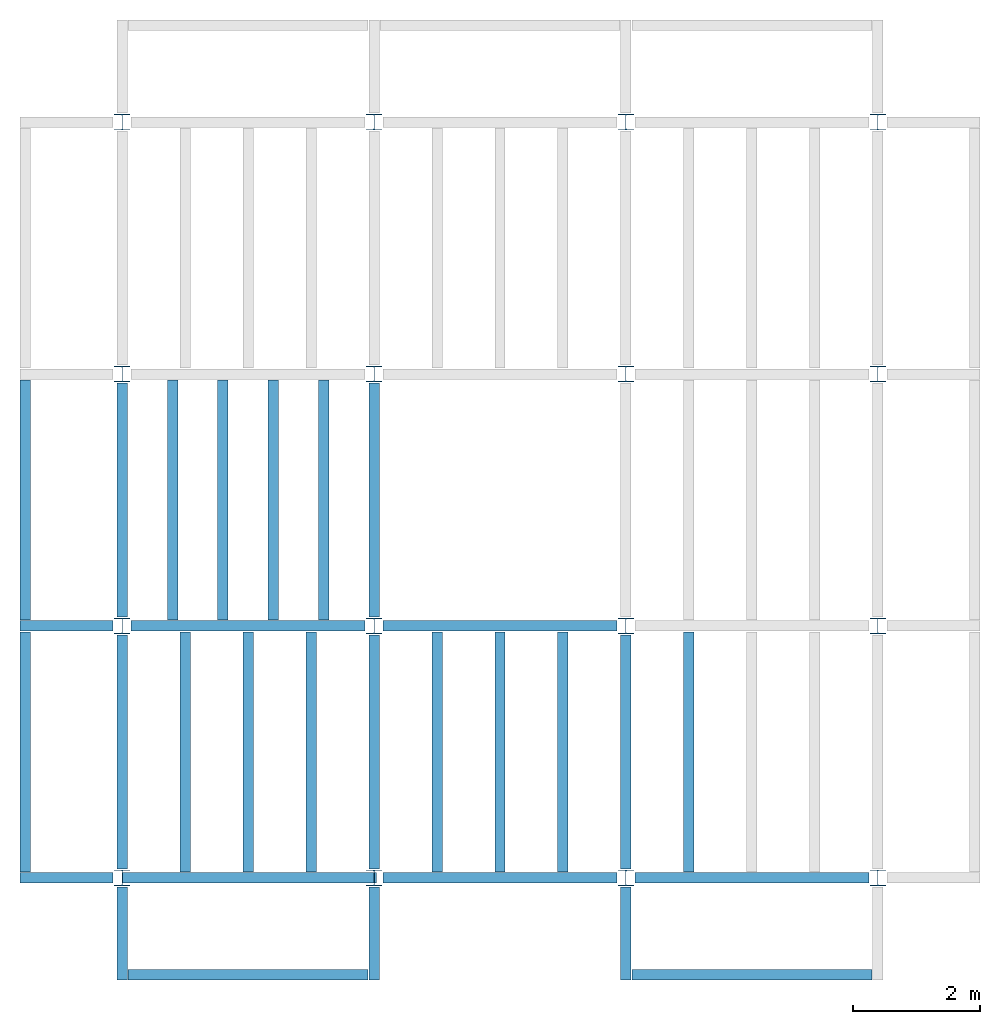
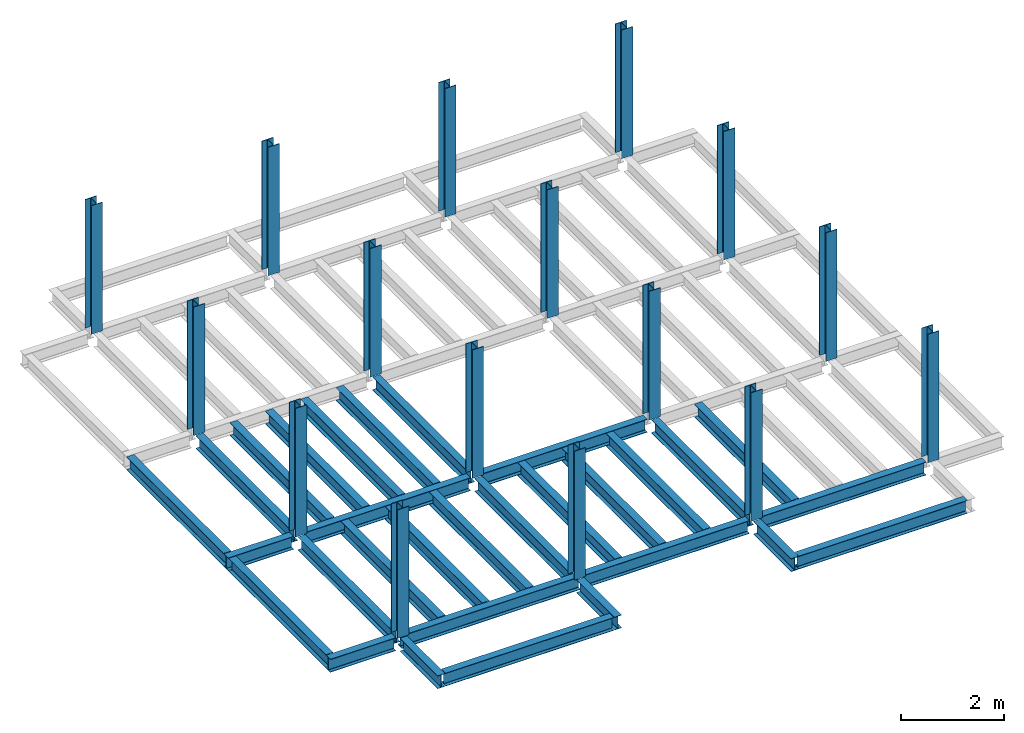
# One storey, part 1 of 3: 30 beams, 16 columns, 4 elements without a shape of their own.
"""IFC4 building model written with IfcOpenShell, lengths in feet."""

from ifc_helpers import new_model, entity, si_unit, converted_unit, derived_unit, direction, frame, origin, origin_2d, place, context, subcontext, project, spatial, line, arc, indexed_curve, i_section, outline, extrude, source, transform, mapped, material, type_object, type_shapes, element, aggregate, save


model = new_model("IFC4")

# Units and contexts
model_context = context("Model", 3, precision=0.0001, world=origin(), true_north=direction((6.123233995736766e-17, 1.0)))
plan_context = context("Plan", 3, precision=0.0001, world=origin(), true_north=direction((6.123233995736766e-17, 1.0)))
body_context = subcontext(model_context, "Body", "Model", "MODEL_VIEW")
ifc_project = project(units=[converted_unit("LENGTHUNIT", "FOOT", entity("IfcLengthMeasure", 0.3048), si_unit("LENGTHUNIT", "METRE"), dimensions=[1, 0, 0, 0, 0, 0, 0]), converted_unit("AREAUNIT", "SQUARE FOOT", entity("IfcAreaMeasure", 0.09290304), si_unit("AREAUNIT", "SQUARE_METRE"), dimensions=[2, 0, 0, 0, 0, 0, 0]), converted_unit("PLANEANGLEUNIT", "DEGREE", entity("IfcPlaneAngleMeasure", 0.017453292519943278), si_unit("PLANEANGLEUNIT", "RADIAN"), dimensions=[0, 0, 0, 0, 0, 0, 0]), converted_unit("VOLUMEUNIT", "CUBIC FOOT", entity("IfcVolumeMeasure", 0.028316846592000004), si_unit("VOLUMEUNIT", "CUBIC_METRE"), dimensions=[3, 0, 0, 0, 0, 0, 0]), si_unit("PRESSUREUNIT", "PASCAL"), derived_unit("MASSDENSITYUNIT", [(si_unit("MASSUNIT", "GRAM", prefix="KILO"), 1), (si_unit("LENGTHUNIT", "METRE"), -3)]), derived_unit("VAPORPERMEABILITYUNIT", [(si_unit("LENGTHUNIT", "METRE"), -1), (si_unit("TIMEUNIT", "SECOND"), 1)]), derived_unit("USERDEFINED", [(si_unit("MASSUNIT", "GRAM", prefix="KILO"), 1), (si_unit("LENGTHUNIT", "METRE"), 3), (si_unit("TIMEUNIT", "SECOND"), -3), (si_unit("ELECTRICCURRENTUNIT", "AMPERE"), -2)]), derived_unit("MODULUSOFELASTICITYUNIT", [(si_unit("MASSUNIT", "GRAM", prefix="KILO"), 1), (si_unit("LENGTHUNIT", "METRE"), -1), (si_unit("TIMEUNIT", "SECOND"), -2)]), derived_unit("THERMALEXPANSIONCOEFFICIENTUNIT", [(si_unit("THERMODYNAMICTEMPERATUREUNIT", "KELVIN"), -1)]), derived_unit("SPECIFICHEATCAPACITYUNIT", [(si_unit("TIMEUNIT", "SECOND"), -2), (si_unit("THERMODYNAMICTEMPERATUREUNIT", "KELVIN"), -1), (si_unit("LENGTHUNIT", "METRE"), 2)]), derived_unit("THERMALCONDUCTANCEUNIT", [(si_unit("MASSUNIT", "GRAM", prefix="KILO"), 1), (si_unit("TIMEUNIT", "SECOND"), -3), (si_unit("THERMODYNAMICTEMPERATUREUNIT", "KELVIN"), -1), (si_unit("LENGTHUNIT", "METRE"), 1)])], contexts=[model_context, plan_context])

# Site, building, storey
site_placement = place(None, origin())
site = spatial("IfcSite", under=ifc_project, at=site_placement, CompositionType="ELEMENT")
building_placement = place(site_placement, origin())
building = spatial("IfcBuilding", under=site, at=building_placement, CompositionType="ELEMENT")
storey_placement = place(building_placement, frame((0.0, 0.0, 69.875)))
storey = spatial("IfcBuildingStorey", under=building, at=storey_placement, Name="STR 08", CompositionType="ELEMENT", Elevation=69.875)

# Columns
ifc_material = material(Name="Steel ASTM A992", Category="Metal")
column_type = type_object("IfcColumnType", Name="W10X49", PredefinedType="COLUMN", material=ifc_material)
shared_shape_1 = source(origin(), body_context, "Body", "SweptSolid", [
    extrude(outline(indexed_curve([(-0.41666666666666663, -0.4166666666666676), (0.41666666666666663, -0.4166666666666676), (0.41666666666666663, -0.3699999999999996), (0.055833333333333846, -0.3699999999999996), (0.02637055078389421, -0.35779611588277277), (0.014166666666666636, -0.32833333333333287), (0.01416666666666665, 0.32833333333333303), (0.026370550783893467, 0.3577961158827727), (0.05583333333333332, 0.3700000000000003), (0.41666666666666663, 0.3700000000000003), (0.41666666666666663, 0.4166666666666656), (-0.41666666666666663, 0.4166666666666656), (-0.41666666666666663, 0.3700000000000003), (-0.05583333333333365, 0.3700000000000003), (-0.02637055078389416, 0.3577961158827734), (-0.014166666666666685, 0.32833333333333387), (-0.014166666666666685, -0.32833333333333264), (-0.026370550783893578, -0.3577961158827721), (-0.055833333333333374, -0.3699999999999996), (-0.41666666666666663, -0.3699999999999996)], segments=[line(1, 2, 3, 4), arc(4, 5, 6), line(6, 7), arc(7, 8, 9), line(9, 10, 11, 12, 13, 14), arc(14, 15, 16), line(16, 17), arc(17, 18, 19), line(19, 20, 1)], self_intersect=False)), frame((0.0, 0.0, 69.875), z_axis=(0.0, 0.0, 1.0), x_axis=(-1.0, 0.0, 0.0)), (0.0, 0.0, 1.0), 10.0),
])
type_shapes(column_type, [shared_shape_1])
for number, where, z_axis, x_axis, name in (
    (1, (0.0, 0.0, -69.875), (0.0, 0.0, 1.0), (-1.0, 0.0, 0.0), "W10X49"),
    (2, (0.0, 13.0, -69.875), (0.0, 0.0, 1.0), (-1.0, 0.0, 0.0), "W10X49"),
    (3, (0.0, 26.0, -69.875), (0.0, 0.0, 1.0), (-1.0, 0.0, 0.0), "W10X49"),
    (4, (0.0, 39.0, -69.875), (0.0, 0.0, 1.0), (-1.0, 0.0, 0.0), "W10X49"),
    (5, (13.0, 0.0, -69.875), (0.0, 0.0, 1.0), (-1.0, 0.0, 0.0), "W10X49"),
    (6, (13.0, 13.0, -69.875), (0.0, 0.0, 1.0), (-1.0, 0.0, 0.0), "W10X49"),
    (7, (13.0, 26.0, -69.875), (0.0, 0.0, 1.0), (-1.0, 0.0, 0.0), "W10X49"),
    (8, (13.0, 39.0, -69.875), (0.0, 0.0, 1.0), (-1.0, 0.0, 0.0), "W10X49"),
    (9, (26.0, 0.0, -69.875), (0.0, 0.0, 1.0), (-1.0, 0.0, 0.0), "W10X49"),
    (10, (26.0, 13.0, -69.875), (0.0, 0.0, 1.0), (-1.0, 0.0, 0.0), "W10X49"),
    (11, (26.0, 26.0, -69.875), (0.0, 0.0, 1.0), (-1.0, 0.0, 0.0), "W10X49"),
    (12, (26.0, 39.0, -69.875), (0.0, 0.0, 1.0), (-1.0, 0.0, 0.0), "W10X49"),
    (13, (39.0, 0.0, -69.875), (0.0, 0.0, 1.0), (-1.0, 0.0, 0.0), "W10X49"),
    (14, (39.0, 13.0, -69.875), (0.0, 0.0, 1.0), (-1.0, 0.0, 0.0), "W10X49"),
    (15, (39.0, 26.0, -69.875), (0.0, 0.0, 1.0), (-1.0, 0.0, 0.0), "W10X49"),
    (16, (39.0, 39.0, -69.875), (0.0, 0.0, 1.0), (-1.0, 0.0, 0.0), "W10X49"),
):
    element("IfcColumn", number, at=place(storey_placement, frame(where, z_axis=z_axis, x_axis=x_axis)), inside=storey, type_object=column_type, material=ifc_material, Name=name, ObjectType="W Shapes-Column:W10X49", PredefinedType="COLUMN", context=body_context, shape_type="MappedRepresentation", body=[
        mapped(shared_shape_1, transform((0.0, 0.0, 0.0), scale=1.0)),
    ])

# Beams
beam_type_1 = type_object("IfcBeamType", Name="W12X26", PredefinedType="JOIST", material=ifc_material)
shared_shape_2 = source(origin(), body_context, "Body", "SweptSolid", [
    extrude(outline(indexed_curve([(-0.27041666666666714, -0.47666666666666574), (-0.27041666666666714, -0.5083333333333351), (0.2704166666666669, -0.5083333333333351), (0.2704166666666669, -0.47666666666666574), (0.03458333333333309, -0.47666666666666574), (0.016905663803669493, -0.46934433619632937), (0.009583333333333202, -0.4516666666666659), (0.0095833333333332, 0.45166666666666705), (0.01690566380366948, 0.4693443361963307), (0.03458333333333325, 0.4766666666666671), (0.2704166666666669, 0.4766666666666671), (0.2704166666666669, 0.5083333333333312), (-0.2704166666666655, 0.5083333333333312), (-0.2704166666666655, 0.4766666666666671), (-0.034583333333333514, 0.47666666666666707), (-0.016905663803669865, 0.46934433619633054), (-0.009583333333333737, 0.45166666666666694), (-0.009583333333333735, -0.4516666666666658), (-0.01690566380367013, -0.4693443361963295), (-0.03458333333333368, -0.47666666666666574)], segments=[line(1, 2, 3, 4, 5), arc(5, 6, 7), line(7, 8), arc(8, 9, 10), line(10, 11, 12, 13, 14, 15), arc(15, 16, 17), line(17, 18), arc(18, 19, 20), line(20, 1)], self_intersect=False)), frame((-6.103346456692914, 0.0, 0.0), z_axis=(-1.0, 0.0, 0.0), x_axis=(0.0, -1.0, 0.0)), (0.0, 0.0, -1.0), 12.083333333333323),
])
type_shapes(beam_type_1, [shared_shape_2])
beam_1_placement = place(storey_placement, frame((6.561679790026266, 13.0, -0.50833333333334)))
element("IfcBeam", 17, at=beam_1_placement, inside=storey, type_object=beam_type_1, material=ifc_material, Name="W12X26", ObjectType="W Shapes:W12X26", PredefinedType="JOIST", context=body_context, shape_type="MappedRepresentation", body=[
    mapped(shared_shape_2, transform((0.0, 0.0, 0.0), scale=1.0)),
])
for number, where, z_axis, x_axis, name in (
    (18, (0.0, 6.561679790026247, -0.50833333333334), (0.0, 0.0, 1.0), (0.0, 1.0, 0.0), "W12X26"),
    (19, (26.0, 6.561679790026162, -0.50833333333334), (0.0, 0.0, 1.0), (0.0, 1.0, 0.0), "W12X26"),
    (20, (13.0, 6.561679790026204, -0.50833333333334), (0.0, 0.0, 1.0), (0.0, 1.0, 0.0), "W12X26"),
):
    element("IfcBeam", number, at=place(storey_placement, frame(where, z_axis=z_axis, x_axis=x_axis)), inside=storey, type_object=beam_type_1, material=ifc_material, Name=name, ObjectType="W Shapes:W12X26", PredefinedType="JOIST", context=body_context, shape_type="MappedRepresentation", body=[
        mapped(shared_shape_2, transform((0.0, 0.0, 0.0), scale=1.0)),
    ])
beam_type_2 = type_object("IfcBeamType", Name="W12X26", PredefinedType="JOIST", material=ifc_material)
shared_shape_3 = source(origin(), body_context, "Body", "SweptSolid", [
    extrude(outline(indexed_curve([(-0.27041666666666714, -0.47666666666666574), (-0.27041666666666714, -0.5083333333333351), (0.2704166666666669, -0.5083333333333351), (0.2704166666666669, -0.47666666666666574), (0.03458333333333309, -0.47666666666666574), (0.016905663803669493, -0.46934433619632937), (0.009583333333333202, -0.4516666666666659), (0.0095833333333332, 0.45166666666666705), (0.01690566380366948, 0.4693443361963307), (0.03458333333333325, 0.4766666666666671), (0.2704166666666669, 0.4766666666666671), (0.2704166666666669, 0.5083333333333312), (-0.2704166666666655, 0.5083333333333312), (-0.2704166666666655, 0.4766666666666671), (-0.034583333333333514, 0.47666666666666707), (-0.016905663803669865, 0.46934433619633054), (-0.009583333333333737, 0.45166666666666694), (-0.009583333333333735, -0.4516666666666658), (-0.01690566380367013, -0.4693443361963295), (-0.03458333333333368, -0.47666666666666574)], segments=[line(1, 2, 3, 4, 5), arc(5, 6, 7), line(7, 8), arc(8, 9, 10), line(10, 11, 12, 13, 14, 15), arc(15, 16, 17), line(17, 18), arc(18, 19, 20), line(20, 1)], self_intersect=False)), frame((-6.226706036745409, 0.0, 0.0), z_axis=(-1.0, 0.0, 0.0), x_axis=(0.0, -1.0, 0.0)), (0.0, 0.0, -1.0), 12.08333333333333),
])
type_shapes(beam_type_2, [shared_shape_3])
for number, where, name in (
    (21, (19.68503937007876, 13.0, -0.50833333333334), "W12X26"),
    (22, (19.68503937007874, 0.0, -0.50833333333334), "W12X26"),
):
    element("IfcBeam", number, at=place(storey_placement, frame(where)), inside=storey, type_object=beam_type_2, material=ifc_material, Name=name, ObjectType="W Shapes:W12X26", PredefinedType="JOIST", context=body_context, shape_type="MappedRepresentation", body=[
        mapped(shared_shape_3, transform((0.0, 0.0, 0.0), scale=1.0)),
    ])
for number, where, z_axis, x_axis, name in (
    (23, (0.0, 19.68503937007874, -0.50833333333334), (0.0, 0.0, 1.0), (0.0, 1.0, 0.0), "W12X26"),
    (24, (13.0, 19.685039370078698, -0.50833333333334), (0.0, 0.0, 1.0), (0.0, 1.0, 0.0), "W12X26"),
):
    element("IfcBeam", number, at=place(storey_placement, frame(where, z_axis=z_axis, x_axis=x_axis)), inside=storey, type_object=beam_type_2, material=ifc_material, Name=name, ObjectType="W Shapes:W12X26", PredefinedType="JOIST", context=body_context, shape_type="MappedRepresentation", body=[
        mapped(shared_shape_3, transform((0.0, 0.0, 0.0), scale=1.0)),
    ])

# Assembly, beams
assembly_1_placement = place(storey_placement, origin())
assembly_1 = element("IfcElementAssembly", 25, at=assembly_1_placement, inside=storey, Name="Structural Framing System", ObjectType="Structural Beam System:Structural Framing System", AssemblyPlace="NOTDEFINED", PredefinedType="BEAM_GRID")
beam_type_3 = type_object("IfcBeamType", Name="W12X26", PredefinedType="JOIST", material=ifc_material)
shared_shape_4 = source(origin(), body_context, "Body", "SweptSolid", [
    extrude(outline(indexed_curve([(-0.27041666666666714, -0.47666666666666574), (-0.27041666666666714, -0.5083333333333351), (0.2704166666666669, -0.5083333333333351), (0.2704166666666669, -0.47666666666666574), (0.03458333333333309, -0.47666666666666574), (0.016905663803669493, -0.46934433619632937), (0.009583333333333202, -0.4516666666666659), (0.0095833333333332, 0.45166666666666705), (0.01690566380366948, 0.4693443361963307), (0.03458333333333325, 0.4766666666666671), (0.2704166666666669, 0.4766666666666671), (0.2704166666666669, 0.5083333333333312), (-0.2704166666666655, 0.5083333333333312), (-0.2704166666666655, 0.4766666666666671), (-0.034583333333333514, 0.47666666666666707), (-0.016905663803669865, 0.46934433619633054), (-0.009583333333333737, 0.45166666666666694), (-0.009583333333333735, -0.4516666666666658), (-0.01690566380367013, -0.4693443361963295), (-0.03458333333333368, -0.47666666666666574)], segments=[line(1, 2, 3, 4, 5), arc(5, 6, 7), line(7, 8), arc(8, 9, 10), line(10, 11, 12, 13, 14, 15), arc(15, 16, 17), line(17, 18), arc(18, 19, 20), line(20, 1)], self_intersect=False)), frame((-6.187916666666566, 0.0, 0.0), z_axis=(-1.0, 0.0, 0.0), x_axis=(0.0, -1.0, 0.0)), (0.0, 0.0, -1.0), 12.375833333333075),
])
type_shapes(beam_type_3, [shared_shape_4])
beam_2_placement = place(assembly_1_placement, frame((3.250000000000031, 6.499999999999844, -0.50833333333334), z_axis=(0.0, 0.0, 1.0), x_axis=(0.0, 1.0, 0.0)))
beam_2 = element("IfcBeam", 26, at=beam_2_placement, type_object=beam_type_3, material=ifc_material, Name="W12X26", ObjectType="W Shapes:W12X26", PredefinedType="JOIST", context=body_context, shape_type="MappedRepresentation", body=[
    mapped(shared_shape_4, transform((0.0, 0.0, 0.0), scale=1.0)),
])
beam_3_placement = place(assembly_1_placement, frame((6.500000000000053, 6.4999999999998455, -0.50833333333334), z_axis=(0.0, 0.0, 1.0), x_axis=(0.0, 1.0, 0.0)))
beam_3 = element("IfcBeam", 27, at=beam_3_placement, type_object=beam_type_3, material=ifc_material, Name="W12X26", ObjectType="W Shapes:W12X26", PredefinedType="JOIST", context=body_context, shape_type="MappedRepresentation", body=[
    mapped(shared_shape_4, transform((0.0, 0.0, 0.0), scale=1.0)),
])
beam_4_placement = place(assembly_1_placement, frame((9.750000000000075, 6.499999999999844, -0.50833333333334), z_axis=(0.0, 0.0, 1.0), x_axis=(0.0, 1.0, 0.0)))
beam_4 = element("IfcBeam", 28, at=beam_4_placement, type_object=beam_type_3, material=ifc_material, Name="W12X26", ObjectType="W Shapes:W12X26", PredefinedType="JOIST", context=body_context, shape_type="MappedRepresentation", body=[
    mapped(shared_shape_4, transform((0.0, 0.0, 0.0), scale=1.0)),
])
aggregate(assembly_1, [beam_2, beam_3, beam_4])

assembly_2_placement = place(storey_placement, origin())
assembly_2 = element("IfcElementAssembly", 29, at=assembly_2_placement, inside=storey, Name="Structural Framing System", ObjectType="Structural Beam System:Structural Framing System", AssemblyPlace="NOTDEFINED", PredefinedType="BEAM_GRID")
beam_5_placement = place(assembly_2_placement, frame((2.6000000000000476, 19.49999999999968, -0.50833333333334), z_axis=(0.0, 0.0, 1.0), x_axis=(0.0, 1.0, 0.0)))
beam_5 = element("IfcBeam", 30, at=beam_5_placement, type_object=beam_type_3, material=ifc_material, Name="W12X26", ObjectType="W Shapes:W12X26", PredefinedType="JOIST", context=body_context, shape_type="MappedRepresentation", body=[
    mapped(shared_shape_4, transform((0.0, 0.0, 0.0), scale=1.0)),
])
beam_6_placement = place(assembly_2_placement, frame((5.200000000000064, 19.499999999999673, -0.50833333333334), z_axis=(0.0, 0.0, 1.0), x_axis=(0.0, 1.0, 0.0)))
beam_6 = element("IfcBeam", 31, at=beam_6_placement, type_object=beam_type_3, material=ifc_material, Name="W12X26", ObjectType="W Shapes:W12X26", PredefinedType="JOIST", context=body_context, shape_type="MappedRepresentation", body=[
    mapped(shared_shape_4, transform((0.0, 0.0, 0.0), scale=1.0)),
])
beam_7_placement = place(assembly_2_placement, frame((7.800000000000081, 19.499999999999666, -0.50833333333334), z_axis=(0.0, 0.0, 1.0), x_axis=(0.0, 1.0, 0.0)))
beam_7 = element("IfcBeam", 32, at=beam_7_placement, type_object=beam_type_3, material=ifc_material, Name="W12X26", ObjectType="W Shapes:W12X26", PredefinedType="JOIST", context=body_context, shape_type="MappedRepresentation", body=[
    mapped(shared_shape_4, transform((0.0, 0.0, 0.0), scale=1.0)),
])

assembly_3_placement = place(storey_placement, origin())
assembly_3 = element("IfcElementAssembly", 33, at=assembly_3_placement, inside=storey, Name="Structural Framing System", ObjectType="Structural Beam System:Structural Framing System", AssemblyPlace="NOTDEFINED", PredefinedType="BEAM_GRID")
beam_8_placement = place(assembly_3_placement, frame((16.250000000000092, 6.499999999999801, -0.50833333333334), z_axis=(0.0, 0.0, 1.0), x_axis=(0.0, 1.0, 0.0)))
beam_8 = element("IfcBeam", 34, at=beam_8_placement, type_object=beam_type_3, material=ifc_material, Name="W12X26", ObjectType="W Shapes:W12X26", PredefinedType="JOIST", context=body_context, shape_type="MappedRepresentation", body=[
    mapped(shared_shape_4, transform((0.0, 0.0, 0.0), scale=1.0)),
])
beam_9_placement = place(assembly_3_placement, frame((19.5000000000001, 6.499999999999801, -0.50833333333334), z_axis=(0.0, 0.0, 1.0), x_axis=(0.0, 1.0, 0.0)))
beam_9 = element("IfcBeam", 35, at=beam_9_placement, type_object=beam_type_3, material=ifc_material, Name="W12X26", ObjectType="W Shapes:W12X26", PredefinedType="JOIST", context=body_context, shape_type="MappedRepresentation", body=[
    mapped(shared_shape_4, transform((0.0, 0.0, 0.0), scale=1.0)),
])
beam_10_placement = place(assembly_3_placement, frame((22.750000000000107, 6.499999999999801, -0.50833333333334), z_axis=(0.0, 0.0, 1.0), x_axis=(0.0, 1.0, 0.0)))
beam_10 = element("IfcBeam", 36, at=beam_10_placement, type_object=beam_type_3, material=ifc_material, Name="W12X26", ObjectType="W Shapes:W12X26", PredefinedType="JOIST", context=body_context, shape_type="MappedRepresentation", body=[
    mapped(shared_shape_4, transform((0.0, 0.0, 0.0), scale=1.0)),
])
aggregate(assembly_3, [beam_8, beam_9, beam_10])

# Assembly, beam
assembly_4_placement = place(storey_placement, origin())
assembly_4 = element("IfcElementAssembly", 37, at=assembly_4_placement, inside=storey, Name="Structural Framing System", ObjectType="Structural Beam System:Structural Framing System", AssemblyPlace="NOTDEFINED", PredefinedType="BEAM_GRID")
beam_11_placement = place(assembly_4_placement, frame((29.2500000000001, 6.49999999999975, -0.50833333333334), z_axis=(0.0, 0.0, 1.0), x_axis=(0.0, 1.0, 0.0)))
beam_11 = element("IfcBeam", 38, at=beam_11_placement, type_object=beam_type_3, material=ifc_material, Name="W12X26", ObjectType="W Shapes:W12X26", PredefinedType="JOIST", context=body_context, shape_type="MappedRepresentation", body=[
    mapped(shared_shape_4, transform((0.0, 0.0, 0.0), scale=1.0)),
])
aggregate(assembly_4, [beam_11])

# Beam
beam_12_placement = place(assembly_2_placement, frame((10.400000000000098, 19.499999999999652, -0.50833333333334), z_axis=(0.0, 0.0, 1.0), x_axis=(0.0, 1.0, 0.0)))
beam_12 = element("IfcBeam", 39, at=beam_12_placement, type_object=beam_type_3, material=ifc_material, Name="W Shapes:W12X26", ObjectType="W Shapes:W12X26", PredefinedType="JOIST", context=body_context, shape_type="MappedRepresentation", body=[
    mapped(shared_shape_4, transform((0.0, 0.0, 0.0), scale=1.0)),
])

aggregate(assembly_2, [beam_5, beam_6, beam_7, beam_12])

# Beams
for number, where, z_axis, x_axis, name in (
    (40, (-5.0, 6.499999999999858, -0.50833333333334), (0.0, 0.0, 1.0), (0.0, -1.0, 0.0), "W12X26"),
    (41, (-5.0, 19.499999999999705, -0.50833333333334), (0.0, 0.0, 1.0), (0.0, 1.0, 0.0), "W12X26"),
):
    element("IfcBeam", number, at=place(storey_placement, frame(where, z_axis=z_axis, x_axis=x_axis)), inside=storey, type_object=beam_type_3, material=ifc_material, Name=name, ObjectType="W Shapes:W12X26", PredefinedType="JOIST", context=body_context, shape_type="MappedRepresentation", body=[
        mapped(shared_shape_4, transform((0.0, 0.0, 0.0), scale=1.0)),
    ])
beam_type_4 = type_object("IfcBeamType", Name="W12X26", PredefinedType="JOIST", material=ifc_material)
shared_shape_5 = source(origin(), body_context, "Body", "SweptSolid", [
    extrude(outline(indexed_curve([(-0.27041666666666714, -0.47666666666666574), (-0.27041666666666714, -0.5083333333333351), (0.2704166666666669, -0.5083333333333351), (0.2704166666666669, -0.47666666666666574), (0.03458333333333309, -0.47666666666666574), (0.016905663803669493, -0.46934433619632937), (0.009583333333333202, -0.4516666666666659), (0.0095833333333332, 0.45166666666666705), (0.01690566380366948, 0.4693443361963307), (0.03458333333333325, 0.4766666666666671), (0.2704166666666669, 0.4766666666666671), (0.2704166666666669, 0.5083333333333312), (-0.2704166666666655, 0.5083333333333312), (-0.2704166666666655, 0.4766666666666671), (-0.034583333333333514, 0.47666666666666707), (-0.016905663803669865, 0.46934433619633054), (-0.009583333333333737, 0.45166666666666694), (-0.009583333333333735, -0.4516666666666658), (-0.01690566380367013, -0.4693443361963295), (-0.03458333333333368, -0.47666666666666574)], segments=[line(1, 2, 3, 4, 5), arc(5, 6, 7), line(7, 8), arc(8, 9, 10), line(10, 11, 12, 13, 14, 15), arc(15, 16, 17), line(17, 18), arc(18, 19, 20), line(20, 1)], self_intersect=False)), frame((-6.165026246719308, 0.0, 0.0), z_axis=(-1.0, 0.0, 0.0), x_axis=(0.0, -1.0, 0.0)), (0.0, 0.0, -1.0), 12.08333333333334),
])
type_shapes(beam_type_4, [shared_shape_5])
beam_13_placement = place(storey_placement, frame((32.623359580052536, 0.0, -0.50833333333334)))
element("IfcBeam", 42, at=beam_13_placement, inside=storey, type_object=beam_type_4, material=ifc_material, Name="W12X26", ObjectType="W Shapes:W12X26", PredefinedType="JOIST", context=body_context, shape_type="MappedRepresentation", body=[
    mapped(shared_shape_5, transform((0.0, 0.0, 0.0), scale=1.0)),
])
beam_type_5 = type_object("IfcBeamType", Name="W12X26", PredefinedType="JOIST", material=ifc_material)
shared_shape_6 = source(origin(), body_context, "Body", "SweptSolid", [
    extrude(outline(indexed_curve([(0.47666666666666574, -0.2704166666666672), (0.5083333333333351, -0.2704166666666672), (0.5083333333333351, 0.27041666666666686), (0.47666666666666574, 0.27041666666666686), (0.47666666666666574, 0.03458333333333307), (0.46934433619632937, 0.016905663803669473), (0.4516666666666659, 0.00958333333333318), (-0.45166666666666705, 0.00958333333333318), (-0.4693443361963307, 0.01690566380366946), (-0.4766666666666671, 0.03458333333333323), (-0.4766666666666671, 0.27041666666666686), (-0.5083333333333312, 0.27041666666666686), (-0.5083333333333312, -0.27041666666666553), (-0.4766666666666671, -0.27041666666666553), (-0.47666666666666707, -0.034583333333333535), (-0.46934433619633054, -0.016905663803669885), (-0.45166666666666694, -0.00958333333333376), (0.4516666666666658, -0.009583333333333756), (0.4693443361963295, -0.01690566380367015), (0.47666666666666574, -0.0345833333333337)], segments=[line(1, 2, 3, 4, 5), arc(5, 6, 7), line(7, 8), arc(8, 9, 10), line(10, 11, 12, 13, 14, 15), arc(15, 16, 17), line(17, 18), arc(18, 19, 20), line(20, 1)], self_intersect=False)), frame((-2.0416666666666208, 0.0, 0.0), z_axis=(1.0, 0.0, 0.0), x_axis=(0.0, 0.0, -1.0)), (0.0, 0.0, 1.0), 4.812083333333336),
])
type_shapes(beam_type_5, [shared_shape_6])
for number, where, z_axis, x_axis, name in (
    (43, (26.0, -2.500000000000538, -0.50833333333334), (0.0, 0.0, 1.0), (0.0, -1.0, 0.0), "W12X26"),
    (44, (-2.499999999999853, 13.0, -0.50833333333334), (0.0, 0.0, 1.0), (-1.0, 0.0, 0.0), "W12X26"),
    (45, (-2.4999999999998743, 0.0, -0.50833333333334), (0.0, 0.0, 1.0), (-1.0, 0.0, 0.0), "W12X26"),
):
    element("IfcBeam", number, at=place(storey_placement, frame(where, z_axis=z_axis, x_axis=x_axis)), inside=storey, type_object=beam_type_5, material=ifc_material, Name=name, ObjectType="W Shapes:W12X26", PredefinedType="JOIST", context=body_context, shape_type="MappedRepresentation", body=[
        mapped(shared_shape_6, transform((0.0, 0.0, 0.0), scale=1.0)),
    ])
beam_type_6 = type_object("IfcBeamType", Name="W12X26", PredefinedType="JOIST", material=ifc_material)
shared_shape_7 = source(origin(), body_context, "Body", "SweptSolid", [
    extrude(outline(indexed_curve([(0.47666666666666574, -0.2704166666666672), (0.5083333333333351, -0.2704166666666672), (0.5083333333333351, 0.27041666666666686), (0.47666666666666574, 0.27041666666666686), (0.47666666666666574, 0.03458333333333307), (0.46934433619632937, 0.016905663803669473), (0.4516666666666659, 0.00958333333333318), (-0.45166666666666705, 0.00958333333333318), (-0.4693443361963307, 0.01690566380366946), (-0.4766666666666671, 0.03458333333333323), (-0.4766666666666671, 0.27041666666666686), (-0.5083333333333312, 0.27041666666666686), (-0.5083333333333312, -0.27041666666666553), (-0.4766666666666671, -0.27041666666666553), (-0.47666666666666707, -0.034583333333333535), (-0.46934433619633054, -0.016905663803669885), (-0.45166666666666694, -0.00958333333333376), (0.4516666666666658, -0.009583333333333756), (0.4693443361963295, -0.01690566380367015), (0.47666666666666574, -0.0345833333333337)], segments=[line(1, 2, 3, 4, 5), arc(5, 6, 7), line(7, 8), arc(8, 9, 10), line(10, 11, 12, 13, 14, 15), arc(15, 16, 17), line(17, 18), arc(18, 19, 20), line(20, 1)], self_intersect=False)), frame((-6.187916666666685, 0.0, 0.0), z_axis=(1.0, 0.0, 0.0), x_axis=(0.0, 0.0, -1.0)), (0.0, 0.0, 1.0), 12.375833333333318),
])
type_shapes(beam_type_6, [shared_shape_7])
beam_14_placement = place(storey_placement, frame((32.50000000000002, -5.0, -0.50833333333334)))
element("IfcBeam", 46, at=beam_14_placement, inside=storey, type_object=beam_type_6, material=ifc_material, Name="W Shapes:W12X26", ObjectType="W Shapes:W12X26", PredefinedType="JOIST", context=body_context, shape_type="MappedRepresentation", body=[
    mapped(shared_shape_7, transform((0.0, 0.0, 0.0), scale=1.0)),
])
beam_type_7 = type_object("IfcBeamType", Name="W12X26", PredefinedType="JOIST", material=ifc_material)
shared_shape_8 = source(origin(), body_context, "Body", "SweptSolid", [
    extrude(outline(indexed_curve([(-0.2704166666666641, -0.5083333333333258), (0.27041666666666764, -0.5083333333333258), (0.27041666666666764, -0.47666666666665947), (0.03458333333333563, -0.4766666666666737), (0.01690566380367109, -0.469344336196329), (0.009583333333335275, -0.451666666666668), (0.009583333333335275, 0.451666666666668), (0.01690566380367109, 0.469344336196329), (0.03458333333333563, 0.4766666666666737), (0.2704166666666694, 0.4766666666666737), (0.27041666666666764, 0.50833333333334), (-0.27041666666666586, 0.50833333333334), (-0.27041666666666586, 0.4766666666666737), (-0.03458333333333208, 0.4766666666666737), (-0.016905663803667537, 0.469344336196329), (-0.009583333333331723, 0.451666666666668), (-0.009583333333331723, -0.451666666666668), (-0.016905663803667537, -0.469344336196329), (-0.03458333333333208, -0.47666666666665947), (-0.27041666666666586, -0.47666666666665947)], segments=[line(1, 2, 3, 4), arc(4, 5, 6), line(6, 7), arc(7, 8, 9), line(9, 10, 11, 12, 13, 14), arc(14, 15, 16), line(16, 17), arc(17, 18, 19), line(19, 20, 1)], self_intersect=False)), frame((13.0, -0.45833333333387627, 69.36666666666665), z_axis=(0.0, -1.0, 0.0), x_axis=(-1.0, 0.0, 0.0)), (0.0, 0.0, 1.0), 4.812083333333337),
])
type_shapes(beam_type_7, [shared_shape_8])
beam_15_placement = place(storey_placement, frame((0.0, 0.0, -69.875)))
element("IfcBeam", 47, at=beam_15_placement, inside=storey, type_object=beam_type_7, material=ifc_material, Name="W12X26", ObjectType="W Shapes:W12X26", PredefinedType="JOIST", context=body_context, shape_type="MappedRepresentation", body=[
    mapped(shared_shape_8, transform((0.0, 0.0, 0.0), scale=1.0)),
])
beam_type_8 = type_object("IfcBeamType", Name="W12X26", PredefinedType="JOIST", material=ifc_material)
shared_shape_9 = source(origin(), body_context, "Body", "SweptSolid", [
    extrude(outline(indexed_curve([(-0.5083333333333258, -0.270416666666665), (-0.47666666666665947, -0.270416666666665), (-0.4766666666666737, -0.034583333333333854), (-0.469344336196329, -0.016905663803669313), (-0.451666666666668, -0.009583333333333499), (0.451666666666668, -0.009583333333333499), (0.469344336196329, -0.016905663803669313), (0.4766666666666737, -0.034583333333332966), (0.4766666666666737, -0.27041666666666675), (0.50833333333334, -0.27041666666666675), (0.50833333333334, 0.27041666666666675), (0.4766666666666737, 0.27041666666666764), (0.4766666666666737, 0.034583333333333854), (0.469344336196329, 0.016905663803669313), (0.451666666666668, 0.009583333333333499), (-0.451666666666668, 0.009583333333333499), (-0.469344336196329, 0.016905663803669313), (-0.47666666666665947, 0.034583333333332966), (-0.47666666666665947, 0.27041666666666675), (-0.5083333333333258, 0.27041666666666764)], segments=[line(1, 2, 3), arc(3, 4, 5), line(5, 6), arc(6, 7, 8), line(8, 9, 10, 11, 12, 13), arc(13, 14, 15), line(15, 16), arc(16, 17, 18), line(18, 19, 20, 1)], self_intersect=False)), frame((0.3120833333333186, -5.0, 69.36666666666665), z_axis=(1.0, 0.0, 0.0), x_axis=(0.0, 0.0, -1.0)), (0.0, 0.0, 1.0), 12.37583333333332),
])
type_shapes(beam_type_8, [shared_shape_9])
beam_16_placement = place(storey_placement, frame((0.0, 0.0, -69.875)))
element("IfcBeam", 48, at=beam_16_placement, inside=storey, type_object=beam_type_8, material=ifc_material, Name="W Shapes:W12X26", ObjectType="W Shapes:W12X26", PredefinedType="JOIST", context=body_context, shape_type="MappedRepresentation", body=[
    mapped(shared_shape_9, transform((0.0, 0.0, 0.0), scale=1.0)),
])
beam_type_9 = type_object("IfcBeamType", Name="W12X26", PredefinedType="JOIST", material=ifc_material)
shared_shape_10 = source(origin(), body_context, "Body", "SweptSolid", [
    extrude(outline(indexed_curve([(-0.27041666666666686, -0.5083333333333258), (0.27041666666666553, -0.5083333333333258), (0.27041666666666553, -0.47666666666665947), (0.03458333333333355, -0.4766666666666737), (0.016905663803669275, -0.469344336196329), (0.009583333333333723, -0.451666666666668), (0.009583333333333218, 0.451666666666668), (0.01690566380366942, 0.469344336196329), (0.034583333333333716, 0.4766666666666737), (0.2704166666666672, 0.4766666666666737), (0.2704166666666672, 0.50833333333334), (-0.27041666666666686, 0.50833333333334), (-0.27041666666666686, 0.4766666666666737), (-0.03458333333333308, 0.4766666666666737), (-0.01690566380366875, 0.469344336196329), (-0.009583333333333164, 0.451666666666668), (-0.009583333333332694, -0.451666666666668), (-0.01690566380366881, -0.469344336196329), (-0.03458333333333319, -0.47666666666665947), (-0.27041666666666686, -0.47666666666665947)], segments=[line(1, 2, 3, 4), arc(4, 5, 6), line(6, 7), arc(7, 8, 9), line(9, 10, 11, 12, 13, 14), arc(14, 15, 16), line(16, 17), arc(17, 18, 19), line(19, 20, 1)], self_intersect=False)), frame((0.0, -0.45833333333383364, 69.36666666666665), z_axis=(0.0, -1.0, 0.0), x_axis=(-1.0, 0.0, 0.0)), (0.0, 0.0, 1.0), 4.812083333333337),
])
type_shapes(beam_type_9, [shared_shape_10])
beam_17_placement = place(storey_placement, frame((0.0, 0.0, -69.875)))
element("IfcBeam", 49, at=beam_17_placement, inside=storey, type_object=beam_type_9, material=ifc_material, Name="W12X26", ObjectType="W Shapes:W12X26", PredefinedType="JOIST", context=body_context, shape_type="MappedRepresentation", body=[
    mapped(shared_shape_10, transform((0.0, 0.0, 0.0), scale=1.0)),
])
beam_type_10 = type_object("IfcBeamType", Name="W12X26", PredefinedType="BEAM")
beam_18_placement = place(storey_placement, frame((0.0, 0.0, -0.50833333333334), z_axis=(-1.0, 0.0, 0.0), x_axis=(0.0, -1.0, 0.0)))
element("IfcBeam", 50, at=beam_18_placement, inside=storey, type_object=beam_type_10, material=ifc_material, Name="W12X26", ObjectType="W12X26", context=model_context, shape_type="SweptSolid", body=[
    extrude(i_section(OverallWidth=0.5408333333333333, OverallDepth=1.0166666666666666, WebThickness=0.019166666666666665, FlangeThickness=0.03166666666666666, FilletRadius=0.024999999999999998, at=origin_2d()), origin(), (0.0, 0.0, -1.0), 13.123359580052494),
])

save(model, "model.ifc")
